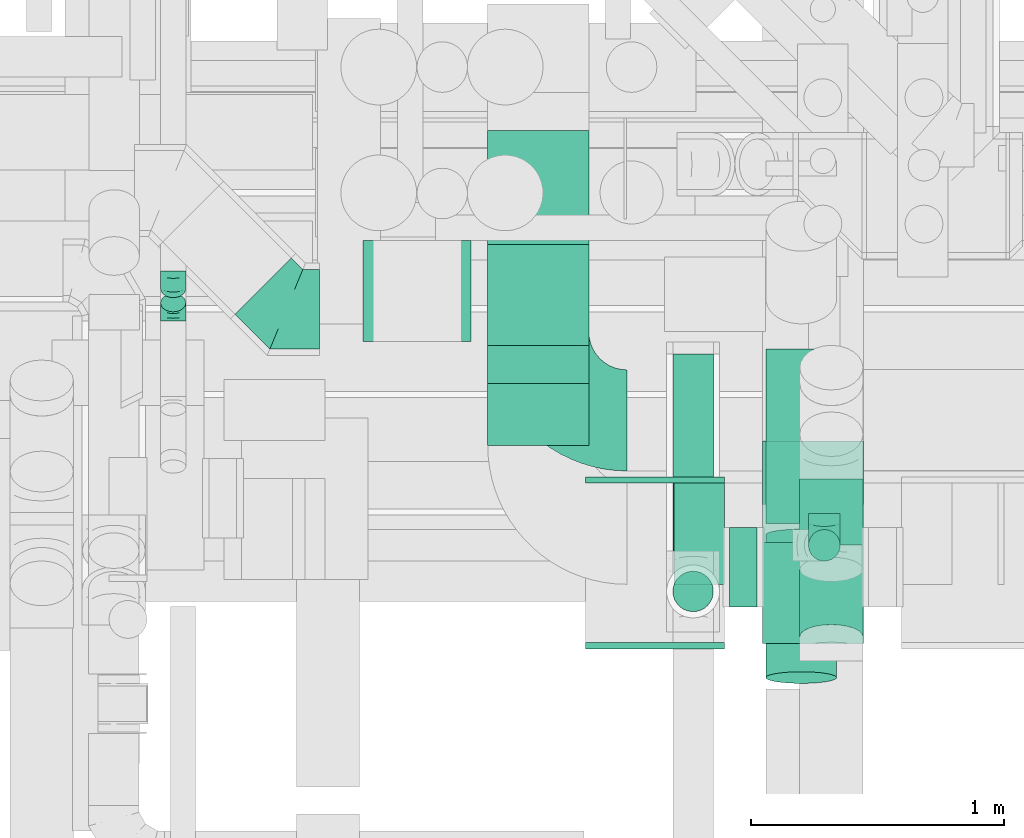
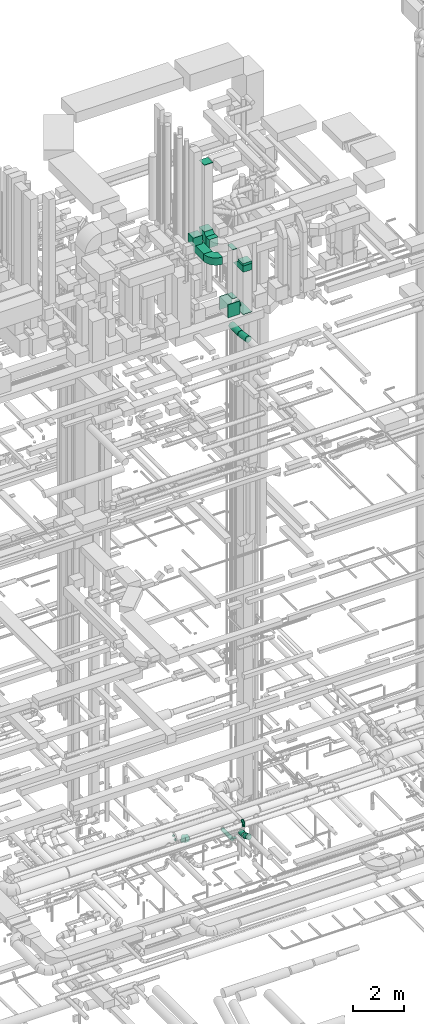
# One storey, part 221 of 337: 13 flow fittings, 12 flow segments.
"""IFC2X3 building model written with IfcOpenShell, lengths in millimetres."""

from ifc_helpers import new_model, entity, si_unit, converted_unit, derived_unit, direction, frame, frame_2d, origin, origin_2d_with_axis, place, context, subcontext, project, spatial, polyline, circle_curve, parameter, trimmed, segment, composite_curve, rectangle, circle, outline, extrude, faceted_brep, source, transform, mapped, material, type_object, type_shapes, element, save


model = new_model("IFC2X3")

# Units and contexts
model_context = context("Model", 3, precision=0.01, world=origin(), true_north=direction((6.12303176911189e-17, 1.0)))
body_context = subcontext(model_context, "Body", "Model", "MODEL_VIEW")
ifc_project = project(units=[si_unit("LENGTHUNIT", "METRE", prefix="MILLI"), si_unit("AREAUNIT", "SQUARE_METRE"), si_unit("VOLUMEUNIT", "CUBIC_METRE"), converted_unit("PLANEANGLEUNIT", "DEGREE", entity("IfcRatioMeasure", 0.0174532925199433), si_unit("PLANEANGLEUNIT", "RADIAN"), dimensions=[0, 0, 0, 0, 0, 0, 0]), si_unit("MASSUNIT", "GRAM", prefix="KILO"), derived_unit("MASSDENSITYUNIT", [(si_unit("MASSUNIT", "GRAM", prefix="KILO"), 1), (si_unit("LENGTHUNIT", "METRE"), -3)]), derived_unit("MOMENTOFINERTIAUNIT", [(si_unit("LENGTHUNIT", "METRE"), 4)]), si_unit("TIMEUNIT", "SECOND"), si_unit("FREQUENCYUNIT", "HERTZ"), si_unit("THERMODYNAMICTEMPERATUREUNIT", "DEGREE_CELSIUS"), derived_unit("THERMALTRANSMITTANCEUNIT", [(si_unit("MASSUNIT", "GRAM", prefix="KILO"), 1), (si_unit("THERMODYNAMICTEMPERATUREUNIT", "KELVIN"), -1), (si_unit("TIMEUNIT", "SECOND"), -3)]), derived_unit("VOLUMETRICFLOWRATEUNIT", [(si_unit("LENGTHUNIT", "METRE"), 3), (si_unit("TIMEUNIT", "SECOND"), -1)]), derived_unit("MASSFLOWRATEUNIT", [(si_unit("MASSUNIT", "GRAM", prefix="KILO"), 1), (si_unit("TIMEUNIT", "SECOND"), -1)]), derived_unit("ROTATIONALFREQUENCYUNIT", [(si_unit("TIMEUNIT", "SECOND"), -1)]), si_unit("ELECTRICCURRENTUNIT", "AMPERE"), si_unit("ELECTRICVOLTAGEUNIT", "VOLT"), si_unit("POWERUNIT", "WATT"), si_unit("FORCEUNIT", "NEWTON", prefix="KILO"), si_unit("ILLUMINANCEUNIT", "LUX"), si_unit("LUMINOUSFLUXUNIT", "LUMEN"), si_unit("LUMINOUSINTENSITYUNIT", "CANDELA"), derived_unit("USERDEFINED", [(si_unit("MASSUNIT", "GRAM", prefix="KILO"), -1), (si_unit("LENGTHUNIT", "METRE"), -2), (si_unit("TIMEUNIT", "SECOND"), 3), (si_unit("LUMINOUSFLUXUNIT", "LUMEN"), 1)]), derived_unit("LINEARVELOCITYUNIT", [(si_unit("LENGTHUNIT", "METRE"), 1), (si_unit("TIMEUNIT", "SECOND"), -1)]), si_unit("PRESSUREUNIT", "PASCAL"), derived_unit("USERDEFINED", [(si_unit("LENGTHUNIT", "METRE"), -2), (si_unit("MASSUNIT", "GRAM", prefix="KILO"), 1), (si_unit("TIMEUNIT", "SECOND"), -2)]), derived_unit("LINEARFORCEUNIT", [(si_unit("MASSUNIT", "GRAM", prefix="KILO"), 1), (si_unit("LENGTHUNIT", "METRE"), 1), (si_unit("TIMEUNIT", "SECOND"), -2), (si_unit("LENGTHUNIT", "METRE"), -1)]), derived_unit("PLANARFORCEUNIT", [(si_unit("MASSUNIT", "GRAM", prefix="KILO"), 1), (si_unit("LENGTHUNIT", "METRE"), 1), (si_unit("TIMEUNIT", "SECOND"), -2), (si_unit("LENGTHUNIT", "METRE"), -2)])], contexts=[model_context])

# Site, building, storey
site_placement = place(None, origin())
site = spatial("IfcSite", under=ifc_project, at=site_placement, CompositionType="ELEMENT")
building_placement = place(site_placement, origin())
building = spatial("IfcBuilding", under=site, at=building_placement, CompositionType="ELEMENT")
storey_placement = place(building_placement, origin())
storey = spatial("IfcBuildingStorey", under=building, at=storey_placement, CompositionType="ELEMENT", Elevation=0.0)

# Flow segments
duct_segment_type_1 = type_object("IfcDuctSegmentType", PredefinedType="NOTDEFINED")
flow_segment_1_placement = place(storey_placement, frame((55811.0, 9186.6, 30600.0)))
element("IfcFlowSegment", 1, at=flow_segment_1_placement, inside=storey, type_object=duct_segment_type_1, context=body_context, shape_type="SweptSolid", body=[
    extrude(rectangle(XDim=796.396645000123, YDim=399.999999999996, at=origin_2d_with_axis()), frame((200.0, 398.2, 0.0), z_axis=(0.0, 0.0, 1.0), x_axis=(0.0, 1.0, 0.0)), (0.0, 0.0, 1.0), 349.999999999998),
])
flow_segment_2_placement = place(storey_placement, frame((56897.0, 7954.29, 30732.17)))
element("IfcFlowSegment", 2, at=flow_segment_2_placement, inside=storey, type_object=duct_segment_type_1, context=body_context, shape_type="SweptSolid", body=[
    extrude(rectangle(XDim=399.999999999996, YDim=400.0, at=origin_2d_with_axis()), frame((200.0, 200.0, 0.0)), (0.0, 0.0, 1.0), 117.830633338824),
])
flow_segment_3_placement = place(storey_placement, frame((55811.0, 8738.29, 31500.0)))
element("IfcFlowSegment", 3, at=flow_segment_3_placement, inside=storey, type_object=duct_segment_type_1, context=body_context, shape_type="SweptSolid", body=[
    extrude(rectangle(XDim=244.711194999999, YDim=399.999999999996, at=origin_2d_with_axis()), frame((200.0, 122.36, 0.0), z_axis=(0.0, 0.0, 1.0), x_axis=(0.0, 1.0, 0.0)), (0.0, 0.0, 1.0), 399.999999999996),
])
flow_segment_4_placement = place(storey_placement, frame((55318.0, 9148.0, 31500.0)))
element("IfcFlowSegment", 4, at=flow_segment_4_placement, inside=storey, type_object=duct_segment_type_1, context=body_context, shape_type="SweptSolid", body=[
    extrude(rectangle(XDim=427.499999999998, YDim=400.0, at=origin_2d_with_axis()), frame((213.75, 200.0, 0.0)), (0.0, 0.0, 1.0), 399.999999999996),
])
duct_segment_type_2 = type_object("IfcDuctSegmentType", PredefinedType="NOTDEFINED")
flow_segment_5_placement = place(storey_placement, frame((57078.31, 8278.42, 3525.0)))
element("IfcFlowSegment", 5, at=flow_segment_5_placement, inside=storey, type_object=duct_segment_type_2, context=body_context, shape_type="SweptSolid", body=[
    extrude(circle(Radius=62.5, at=origin_2d_with_axis()), frame((64.1, 64.1, 0.0), z_axis=(0.0, 0.0, 1.0), x_axis=(0.0, 1.0, 0.0)), (0.0, 0.0, 1.0), 84.9999999999742),
])
flow_segment_6_placement = place(storey_placement, frame((56909.56, 8429.56, 27017.13)))
element("IfcFlowSegment", 6, at=flow_segment_6_placement, inside=storey, type_object=duct_segment_type_2, context=body_context, shape_type="SweptSolid", body=[
    extrude(circle(Radius=140.0, at=origin_2d_with_axis()), frame((141.6, 0.0, 141.6), z_axis=(0.0, 1.0, 0.0), x_axis=(-1.0, 0.0, 0.0)), (0.0, 0.0, 1.0), 689.86615875724),
])
flow_segment_7_placement = place(storey_placement, frame((56767.0, 8097.11, 28635.9)))
element("IfcFlowSegment", 7, at=flow_segment_7_placement, inside=storey, type_object=duct_segment_type_2, context=body_context, shape_type="SweptSolid", body=[
    extrude(circle(Radius=157.5, at=origin_2d_with_axis()), frame((0.0, 159.1, 159.1), z_axis=(1.0, 0.0, 0.0), x_axis=(0.0, -1.0, 0.0)), (0.0, 0.0, 1.0), 109.999999999984),
])
flow_segment_8_placement = place(storey_placement, frame((56541.69, 8320.18, 3018.4)))
element("IfcFlowSegment", 8, at=flow_segment_8_placement, inside=storey, type_object=duct_segment_type_2, context=body_context, shape_type="SweptSolid", body=[
    extrude(circle(Radius=80.0, at=origin_2d_with_axis()), frame((81.6, 0.0, 81.6), z_axis=(0.0, 1.0, 0.0), x_axis=(1.0, 0.0, 0.0)), (0.0, 0.0, 1.0), 778.202491666926),
])
flow_segment_9_placement = place(storey_placement, frame((56541.69, 8078.58, 3260.0)))
element("IfcFlowSegment", 9, at=flow_segment_9_placement, inside=storey, type_object=duct_segment_type_2, context=body_context, shape_type="SweptSolid", body=[
    extrude(circle(Radius=80.0, at=origin_2d_with_axis()), frame((81.6, 81.6, 0.0), z_axis=(0.0, 0.0, 1.0), x_axis=(-1.0, 0.0, 0.0)), (0.0, 0.0, 1.0), 10.000000000041),
])
flow_segment_10_placement = place(storey_placement, frame((57043.49, 8343.62, 2973.4)))
element("IfcFlowSegment", 10, at=flow_segment_10_placement, inside=storey, type_object=duct_segment_type_2, context=body_context, shape_type="SweptSolid", body=[
    extrude(circle(Radius=125.0, at=origin_2d_with_axis()), frame((126.6, 0.0, 126.6), z_axis=(0.0, 1.0, 0.0), x_axis=(1.0, 0.0, 0.0)), (0.0, 0.0, 1.0), 261.453983368941),
])
flow_segment_11_placement = place(storey_placement, frame((57043.49, 7930.94, 3002.39)))
element("IfcFlowSegment", 11, at=flow_segment_11_placement, inside=storey, type_object=duct_segment_type_2, context=body_context, shape_type="SweptSolid", body=[
    extrude(circle(Radius=125.0, at=origin_2d_with_axis()), frame((126.6, 49.78, 228.28), z_axis=(0.0, 0.922703438537182, -0.385510524514779), x_axis=(1.0, 0.0, 0.0)), (0.0, 0.0, 1.0), 288.842229168061),
])
flow_segment_12_placement = place(storey_placement, frame((56909.56, 7794.82, 27022.8)))
element("IfcFlowSegment", 12, at=flow_segment_12_placement, inside=storey, type_object=duct_segment_type_2, context=body_context, shape_type="SweptSolid", body=[
    extrude(circle(Radius=140.0, at=origin_2d_with_axis()), frame((141.6, 24.53, 233.42), z_axis=(0.0, 0.986491843597677, -0.163810385858946), x_axis=(-1.0, 0.0, 0.0)), (0.0, 0.0, 1.0), 572.07644729215),
])

# Flow fittings
ifc_material = material()
duct_fitting_type_1 = type_object("IfcDuctFittingType", PredefinedType="NOTDEFINED", material=ifc_material)
shared_shape_1 = source(origin(), body_context, "Body", "SweptSolid", [
    extrude(rectangle(XDim=200.0, YDim=26.096, at=origin_2d_with_axis()), frame((6.95, 0.0, -200.0), z_axis=(0.0, 0.0, 1.0), x_axis=(0.0, -1.0, 0.0)), (0.0, 0.0, 1.0), 400.0),
])
type_shapes(duct_fitting_type_1, [shared_shape_1])
for number, where, z_axis, x_axis in (
    (13, (56647.0, 8388.29, 29132.0), (0.0, 1.0, 0.0), (0.0, 0.0, 1.0)),
    (14, (56647.0, 8388.29, 31500.0), (0.0, 1.0, 0.0), (0.0, 0.0, -1.0)),
):
    element("IfcFlowFitting", number, at=place(storey_placement, frame(where, z_axis=z_axis, x_axis=x_axis)), inside=storey, type_object=duct_fitting_type_1, material=ifc_material, context=body_context, shape_type="MappedRepresentation", body=[
        mapped(shared_shape_1, transform((0.0, 0.0, 0.0), scale=1.0)),
    ])
duct_fitting_type_2 = type_object("IfcDuctFittingType", PredefinedType="NOTDEFINED", material=ifc_material)
shared_shape_2 = source(origin(), body_context, "Body", "SweptSolid", [
    extrude(rectangle(XDim=24.9999999999999, YDim=400.0, at=origin_2d_with_axis()), frame((12.5, 0.0, -200.0)), (0.0, 0.0, 1.0), 400.0),
])
type_shapes(duct_fitting_type_2, [shared_shape_2])
flow_fitting_1_placement = place(storey_placement, frame((56011.0, 9333.0, 35225.17), z_axis=(0.0, -1.0, 0.0), x_axis=(0.0, 0.0, 1.0)))
element("IfcFlowFitting", 15, at=flow_fitting_1_placement, inside=storey, type_object=duct_fitting_type_2, material=ifc_material, context=body_context, shape_type="MappedRepresentation", body=[
    mapped(shared_shape_2, transform((0.0, 0.0, 0.0), scale=1.0)),
])
duct_fitting_type_3 = type_object("IfcDuctFittingType", PredefinedType="NOTDEFINED", material=ifc_material)
shared_shape_3 = source(origin(), body_context, "Body", "SweptSolid", [
    extrude(outline(polyline([(-9.99, -180.02), (489.95, -180.02), (-150.0, 300.04), (-329.96, 60.01), (-9.99, -180.02)])), frame((150.0, -200.0, 99.96), z_axis=(0.0, 1.0, 0.0), x_axis=(0.600077602249012, 0.0, 0.799941792431847)), (0.0, 0.0, 1.0), 400.0),
])
type_shapes(duct_fitting_type_3, [shared_shape_3])
flow_fitting_2_placement = place(storey_placement, frame((57097.0, 8154.29, 30732.17), z_axis=(0.0, 1.0, 0.0), x_axis=(0.0, 0.0, -1.0)))
element("IfcFlowFitting", 16, at=flow_fitting_2_placement, inside=storey, type_object=duct_fitting_type_3, material=ifc_material, context=body_context, shape_type="MappedRepresentation", body=[
    mapped(shared_shape_3, transform((0.0, 0.0, 0.0), scale=1.0)),
])
duct_fitting_type_4 = type_object("IfcDuctFittingType", PredefinedType="NOTDEFINED", material=ifc_material)
shared_shape_4 = source(origin(), body_context, "Body", "SweptSolid", [
    extrude(rectangle(XDim=24.9999999999999, YDim=550.0, at=origin_2d_with_axis()), frame((12.5, 0.0, -315.0)), (0.0, 0.0, 1.0), 630.0),
])
type_shapes(duct_fitting_type_4, [shared_shape_4])
for number, where, z_axis, x_axis in (
    (17, (56472.0, 8588.29, 28817.0), (0.0, 0.0, 1.0), (0.0, 1.0, 0.0)),
    (18, (56472.0, 7958.29, 28817.0), (0.0, 0.0, 1.0), (0.0, -1.0, 0.0)),
):
    element("IfcFlowFitting", number, at=place(storey_placement, frame(where, z_axis=z_axis, x_axis=x_axis)), inside=storey, type_object=duct_fitting_type_4, material=ifc_material, context=body_context, shape_type="MappedRepresentation", body=[
        mapped(shared_shape_4, transform((0.0, 0.0, 0.0), scale=1.0)),
    ])
duct_fitting_type_5 = type_object("IfcDuctFittingType", PredefinedType="NOTDEFINED", material=ifc_material)
shared_shape_5 = source(origin(), body_context, "Body", "SweptSolid", [
    extrude(rectangle(XDim=24.9999999999999, YDim=800.0, at=origin_2d_with_axis()), frame((12.5, 0.0, -200.0)), (0.0, 0.0, 1.0), 400.0),
])
type_shapes(duct_fitting_type_5, [shared_shape_5])
flow_fitting_3_placement = place(storey_placement, frame((57097.0, 8354.21, 28417.57), z_axis=(1.0, 0.0, 0.0), x_axis=(0.0, 0.0, -1.0)))
element("IfcFlowFitting", 19, at=flow_fitting_3_placement, inside=storey, type_object=duct_fitting_type_5, material=ifc_material, context=body_context, shape_type="MappedRepresentation", body=[
    mapped(shared_shape_5, transform((0.0, 0.0, 0.0), scale=1.0)),
])
duct_fitting_type_6 = type_object("IfcDuctFittingType", PredefinedType="NOTDEFINED", material=ifc_material)
shared_shape_6 = source(origin(), body_context, "Body", "Brep", [
    faceted_brep([(-125.0, 0.0, -62.5), (-125.0, -16.18, -60.37), (-125.0, -31.25, -54.13), (-125.0, -44.19, -44.19), (-125.0, -54.13, -31.25), (-125.0, -60.37, -16.18), (-125.0, -62.5, 0.0), (-125.0, -60.37, 16.18), (-125.0, -54.13, 31.25), (-125.0, -44.19, 44.19), (-125.0, -31.25, 54.13), (-125.0, -16.18, 60.37), (-125.0, 0.0, 62.5), (-125.0, 16.18, 60.37), (-125.0, 31.25, 54.13), (-125.0, 44.19, 44.19), (-125.0, 54.13, 31.25), (-125.0, 60.37, 16.18), (-125.0, 62.5, 0.0), (-125.0, 60.37, -16.18), (-125.0, 54.13, -31.25), (-125.0, 44.19, -44.19), (-125.0, 31.25, -54.13), (-125.0, 16.18, -60.37), (-95.84, 16.18, 60.37), (-99.88, 31.25, 54.13), (-91.51, 0.0, 62.5), (-103.35, 44.19, 44.19), (-107.68, 60.37, 16.18), (-108.25, 62.5, 0.0), (-106.01, 54.13, 31.25), (-106.01, 54.13, -31.25), (-103.35, 44.19, -44.19), (-107.68, 60.37, -16.18), (-95.84, 16.18, -60.37), (-91.51, 0.0, -62.5), (-99.88, 31.25, -54.13), (-87.17, -16.18, -60.37), (-83.13, -31.25, -54.13), (-79.66, -44.19, -44.19), (-77.0, -54.13, -31.25), (-75.33, -60.37, -16.18), (-74.76, -62.5, 0.0), (-75.33, -60.37, 16.18), (-77.0, -54.13, 31.25), (-79.66, -44.19, 44.19), (-83.13, -31.25, 54.13), (-87.17, -16.18, 60.37), (-45.34, 45.34, 60.37), (-56.37, 56.37, 54.13), (-33.49, 33.49, 62.5), (-65.85, 65.85, 44.19), (-73.12, 73.12, 31.25), (-77.69, 77.69, 16.18), (-79.25, 79.25, 0.0), (-77.69, 77.69, -16.18), (-73.12, 73.12, -31.25), (-65.85, 65.85, -44.19), (-45.34, 45.34, -60.37), (-33.49, 33.49, -62.5), (-56.37, 56.37, -54.13), (-21.65, 21.65, -60.37), (-10.62, 10.62, -54.13), (-1.14, 1.14, -44.19), (6.13, -6.13, -31.25), (10.7, -10.7, -16.18), (12.26, -12.26, 0.0), (10.7, -10.7, 16.18), (6.13, -6.13, 31.25), (-1.14, 1.14, 44.19), (-10.62, 10.62, 54.13), (-21.65, 21.65, 60.37), (-16.18, 95.84, 60.37), (-31.25, 99.88, 54.13), (0.0, 91.51, 62.5), (-44.19, 103.35, 44.19), (-54.13, 106.01, 31.25), (-60.37, 107.68, 16.18), (-62.5, 108.25, 0.0), (-60.37, 107.68, -16.18), (-54.13, 106.01, -31.25), (-44.19, 103.35, -44.19), (-16.18, 95.84, -60.37), (0.0, 91.51, -62.5), (-31.25, 99.88, -54.13), (16.18, 87.17, -60.37), (31.25, 83.13, -54.13), (44.19, 79.66, -44.19), (54.13, 77.0, -31.25), (60.37, 75.33, -16.18), (62.5, 74.76, 0.0), (60.37, 75.33, 16.18), (54.13, 77.0, 31.25), (44.19, 79.66, 44.19), (31.25, 83.13, 54.13), (16.18, 87.17, 60.37), (-16.18, 125.0, -60.37), (-31.25, 125.0, -54.13), (-44.19, 125.0, -44.19), (-54.13, 125.0, -31.25), (-60.37, 125.0, -16.18), (-62.5, 125.0, 0.0), (-60.37, 125.0, 16.18), (-54.13, 125.0, 31.25), (-44.19, 125.0, 44.19), (-31.25, 125.0, 54.13), (-16.18, 125.0, 60.37), (0.0, 125.0, 62.5), (16.18, 125.0, 60.37), (31.25, 125.0, 54.13), (44.19, 125.0, 44.19), (54.13, 125.0, 31.25), (60.37, 125.0, 16.18), (62.5, 125.0, 0.0), (60.37, 125.0, -16.18), (54.13, 125.0, -31.25), (44.19, 125.0, -44.19), (31.25, 125.0, -54.13), (16.18, 125.0, -60.37), (0.0, 125.0, -62.5)], [[[0, 1, 2, 3, 4, 5, 6, 7, 8, 9, 10, 11, 12, 13, 14, 15, 16, 17, 18, 19, 20, 21, 22, 23]], [[24, 25, 14, 13]], [[26, 24, 13, 12]], [[14, 25, 27, 15]], [[28, 29, 18, 17]], [[30, 28, 17, 16]], [[15, 27, 30, 16]], [[20, 31, 32, 21]], [[33, 31, 20, 19]], [[18, 29, 33, 19]], [[34, 35, 0, 23]], [[36, 34, 23, 22]], [[21, 32, 36, 22]], [[1, 0, 35, 37]], [[2, 1, 37, 38]], [[38, 39, 3, 2]], [[5, 4, 40, 41]], [[6, 5, 41, 42]], [[39, 40, 4, 3]], [[6, 42, 43, 7]], [[7, 43, 44, 8]], [[45, 9, 8, 44]], [[9, 45, 46, 10]], [[10, 46, 47, 11]], [[26, 12, 11, 47]], [[48, 49, 25, 24]], [[50, 48, 24, 26]], [[27, 25, 49, 51]], [[52, 53, 28, 30]], [[51, 52, 30, 27]], [[29, 28, 53, 54]], [[55, 56, 31, 33]], [[54, 55, 33, 29]], [[57, 32, 31, 56]], [[58, 59, 35, 34]], [[60, 58, 34, 36]], [[57, 60, 36, 32]], [[37, 35, 59, 61]], [[38, 37, 61, 62]], [[39, 38, 62, 63]], [[41, 40, 64, 65]], [[42, 41, 65, 66]], [[63, 64, 40, 39]], [[43, 42, 66, 67]], [[44, 43, 67, 68]], [[68, 69, 45, 44]], [[46, 45, 69, 70]], [[47, 46, 70, 71]], [[26, 47, 71, 50]], [[72, 73, 49, 48]], [[74, 72, 48, 50]], [[51, 49, 73, 75]], [[76, 77, 53, 52]], [[75, 76, 52, 51]], [[54, 53, 77, 78]], [[79, 80, 56, 55]], [[78, 79, 55, 54]], [[81, 57, 56, 80]], [[82, 83, 59, 58]], [[84, 82, 58, 60]], [[81, 84, 60, 57]], [[61, 59, 83, 85]], [[62, 61, 85, 86]], [[63, 62, 86, 87]], [[65, 64, 88, 89]], [[66, 65, 89, 90]], [[87, 88, 64, 63]], [[67, 66, 90, 91]], [[68, 67, 91, 92]], [[92, 93, 69, 68]], [[70, 69, 93, 94]], [[71, 70, 94, 95]], [[50, 71, 95, 74]], [[96, 97, 98, 99, 100, 101, 102, 103, 104, 105, 106, 107, 108, 109, 110, 111, 112, 113, 114, 115, 116, 117, 118, 119]], [[72, 74, 107, 106]], [[73, 72, 106, 105]], [[75, 73, 105, 104]], [[77, 76, 103, 102]], [[78, 77, 102, 101]], [[75, 104, 103, 76]], [[78, 101, 100, 79]], [[79, 100, 99, 80]], [[80, 99, 98, 81]], [[96, 119, 83, 82]], [[97, 96, 82, 84]], [[84, 81, 98, 97]], [[83, 119, 118, 85]], [[85, 118, 117, 86]], [[116, 87, 86, 117]], [[88, 115, 114, 89]], [[89, 114, 113, 90]], [[115, 88, 87, 116]], [[91, 90, 113, 112]], [[92, 91, 112, 111]], [[111, 110, 93, 92]], [[95, 94, 109, 108]], [[74, 95, 108, 107]], [[110, 109, 94, 93]]]),
])
type_shapes(duct_fitting_type_6, [shared_shape_6])
flow_fitting_4_placement = place(storey_placement, frame((57142.4, 8342.51, 3735.0), z_axis=(1.0, 0.0, 0.0), x_axis=(0.0, -1.0, 0.0)))
element("IfcFlowFitting", 20, at=flow_fitting_4_placement, inside=storey, type_object=duct_fitting_type_6, material=ifc_material, context=body_context, shape_type="MappedRepresentation", body=[
    mapped(shared_shape_6, transform((0.0, 0.0, 0.0), scale=1.0)),
])
duct_fitting_type_7 = type_object("IfcDuctFittingType", PredefinedType="NOTDEFINED", material=ifc_material)
shared_shape_7 = source(origin(), body_context, "Body", "Brep", [
    faceted_brep([(-41.42, 0.0, -50.0), (-41.42, -12.94, -48.3), (-41.42, -25.0, -43.3), (-41.42, -35.36, -35.36), (-41.42, -43.3, -25.0), (-41.42, -48.3, -12.94), (-41.42, -50.0, 0.0), (-41.42, -48.3, 12.94), (-41.42, -43.3, 25.0), (-41.42, -35.36, 35.36), (-41.42, -25.0, 43.3), (-41.42, -12.94, 48.3), (-41.42, 0.0, 50.0), (-41.42, 12.94, 48.3), (-41.42, 25.0, 43.3), (-41.42, 35.36, 35.36), (-41.42, 43.3, 25.0), (-41.42, 48.3, 12.94), (-41.42, 50.0, 0.0), (-41.42, 48.3, -12.94), (-41.42, 43.3, -25.0), (-41.42, 35.36, -35.36), (-41.42, 25.0, -43.3), (-41.42, 12.94, -48.3), (-24.1, 12.94, 48.3), (-26.5, 25.0, 43.3), (-21.53, 0.0, 50.0), (-28.56, 35.36, 35.36), (-31.14, 48.3, 12.94), (-31.48, 50.0, 0.0), (-30.14, 43.3, 25.0), (-30.14, 43.3, -25.0), (-28.56, 35.36, -35.36), (-31.14, 48.3, -12.94), (-24.1, 12.94, -48.3), (-21.53, 0.0, -50.0), (-26.5, 25.0, -43.3), (-18.96, -12.94, -48.3), (-16.56, -25.0, -43.3), (-14.5, -35.36, -35.36), (-12.92, -43.3, -25.0), (-11.92, -48.3, -12.94), (-11.58, -50.0, 0.0), (-11.92, -48.3, 12.94), (-12.92, -43.3, 25.0), (-14.5, -35.36, 35.36), (-16.56, -25.0, 43.3), (-18.96, -12.94, 48.3), (7.89, 26.19, 48.3), (1.06, 36.42, 43.3), (15.22, 15.22, 50.0), (-4.8, 45.2, 35.36), (-12.13, 56.17, 12.94), (-13.1, 57.61, 0.0), (-9.3, 51.93, 25.0), (-9.3, 51.93, -25.0), (-4.8, 45.2, -35.36), (-12.13, 56.17, -12.94), (7.89, 26.19, -48.3), (15.22, 15.22, -50.0), (1.06, 36.42, -43.3), (22.55, 4.25, -48.3), (29.39, -5.97, -43.3), (35.25, -14.75, -35.36), (39.75, -21.48, -25.0), (42.58, -25.72, -12.94), (43.55, -27.16, 0.0), (42.58, -25.72, 12.94), (39.75, -21.48, 25.0), (35.25, -14.75, 35.36), (29.39, -5.97, 43.3), (22.55, 4.25, 48.3), (29.29, 29.29, 50.0), (20.14, 38.44, 48.3), (11.61, 46.97, 43.3), (4.29, 54.29, 35.36), (-1.33, 59.91, 25.0), (-4.86, 63.44, 12.94), (-6.07, 64.64, 0.0), (-4.86, 63.44, -12.94), (-1.33, 59.91, -25.0), (4.29, 54.29, -35.36), (11.61, 46.97, -43.3), (20.14, 38.44, -48.3), (29.29, 29.29, -50.0), (38.44, 20.14, -48.3), (46.97, 11.61, -43.3), (54.29, 4.29, -35.36), (59.91, -1.33, -25.0), (63.44, -4.86, -12.94), (64.64, -6.07, 0.0), (63.44, -4.86, 12.94), (59.91, -1.33, 25.0), (54.29, 4.29, 35.36), (46.97, 11.61, 43.3), (38.44, 20.14, 48.3)], [[[0, 1, 2, 3, 4, 5, 6, 7, 8, 9, 10, 11, 12, 13, 14, 15, 16, 17, 18, 19, 20, 21, 22, 23]], [[24, 25, 14, 13]], [[26, 24, 13, 12]], [[14, 25, 27, 15]], [[28, 29, 18, 17]], [[30, 28, 17, 16]], [[15, 27, 30, 16]], [[20, 31, 32, 21]], [[33, 31, 20, 19]], [[18, 29, 33, 19]], [[34, 35, 0, 23]], [[36, 34, 23, 22]], [[32, 36, 22, 21]], [[2, 1, 37, 38]], [[3, 2, 38, 39]], [[0, 35, 37, 1]], [[5, 4, 40, 41]], [[6, 5, 41, 42]], [[39, 40, 4, 3]], [[6, 42, 43, 7]], [[7, 43, 44, 8]], [[8, 44, 45, 9]], [[10, 46, 47, 11]], [[11, 47, 26, 12]], [[9, 45, 46, 10]], [[48, 49, 25, 24]], [[50, 48, 24, 26]], [[25, 49, 51, 27]], [[52, 53, 29, 28]], [[54, 52, 28, 30]], [[30, 27, 51, 54]], [[55, 56, 32, 31]], [[57, 55, 31, 33]], [[53, 57, 33, 29]], [[58, 59, 35, 34]], [[60, 58, 34, 36]], [[36, 32, 56, 60]], [[35, 59, 61, 37]], [[38, 37, 61, 62]], [[39, 38, 62, 63]], [[41, 40, 64, 65]], [[42, 41, 65, 66]], [[63, 64, 40, 39]], [[43, 42, 66, 67]], [[44, 43, 67, 68]], [[68, 69, 45, 44]], [[46, 45, 69, 70]], [[47, 46, 70, 71]], [[26, 47, 71, 50]], [[48, 50, 72, 73]], [[49, 48, 73, 74]], [[51, 49, 74, 75]], [[52, 54, 76, 77]], [[53, 52, 77, 78]], [[51, 75, 76, 54]], [[53, 78, 79, 57]], [[57, 79, 80, 55]], [[55, 80, 81, 56]], [[60, 82, 83, 58]], [[58, 83, 84, 59]], [[60, 56, 81, 82]], [[59, 84, 85, 61]], [[61, 85, 86, 62]], [[62, 86, 87, 63]], [[64, 88, 89, 65]], [[65, 89, 90, 66]], [[63, 87, 88, 64]], [[67, 66, 90, 91]], [[68, 67, 91, 92]], [[69, 68, 92, 93]], [[71, 70, 94, 95]], [[50, 71, 95, 72]], [[93, 94, 70, 69]], [[83, 82, 81, 80, 79, 78, 77, 76, 75, 74, 73, 72, 95, 94, 93, 92, 91, 90, 89, 88, 87, 86, 85, 84]]]),
])
type_shapes(duct_fitting_type_7, [shared_shape_7])
flow_fitting_5_placement = place(storey_placement, frame((54566.99, 9387.05, 3340.0), z_axis=(1.0, 0.0, 0.0), x_axis=(0.0, -1.0, -7.37136086970108e-07)))
element("IfcFlowFitting", 21, at=flow_fitting_5_placement, inside=storey, type_object=duct_fitting_type_7, material=ifc_material, context=body_context, shape_type="MappedRepresentation", body=[
    mapped(shared_shape_7, transform((0.0, 0.0, 0.0), scale=1.0)),
])
duct_fitting_type_8 = type_object("IfcDuctFittingType", PredefinedType="NOTDEFINED", material=ifc_material)
type_shapes(duct_fitting_type_8, [shared_shape_7])
flow_fitting_6_placement = place(storey_placement, frame((54566.99, 9272.05, 3225.0), z_axis=(-1.0, 0.0, 0.0), x_axis=(0.0, -0.707106160957612, -0.707107401414939)))
element("IfcFlowFitting", 22, at=flow_fitting_6_placement, inside=storey, type_object=duct_fitting_type_8, material=ifc_material, context=body_context, shape_type="MappedRepresentation", body=[
    mapped(shared_shape_7, transform((0.0, 0.0, 0.0), scale=1.0)),
])
duct_fitting_type_9 = type_object("IfcDuctFittingType", PredefinedType="NOTDEFINED", material=ifc_material)
shared_shape_8 = source(origin(), body_context, "Body", "Brep", [
    faceted_brep([(-130.48, 0.0, -157.5), (-130.48, -40.76, -152.13), (-130.48, -78.75, -136.4), (-130.48, -111.37, -111.37), (-130.48, -136.4, -78.75), (-130.48, -152.13, -40.76), (-130.48, -157.5, 0.0), (-130.48, -152.13, 40.76), (-130.48, -136.4, 78.75), (-130.48, -111.37, 111.37), (-130.48, -78.75, 136.4), (-130.48, -40.76, 152.13), (-130.48, 0.0, 157.5), (-130.48, 40.76, 152.13), (-130.48, 78.75, 136.4), (-130.48, 111.37, 111.37), (-130.48, 136.4, 78.75), (-130.48, 152.13, 40.76), (-130.48, 157.5, 0.0), (-130.48, 152.13, -40.76), (-130.48, 136.4, -78.75), (-130.48, 111.37, -111.37), (-130.48, 78.75, -136.4), (-130.48, 40.76, -152.13), (-16.89, 40.76, 152.13), (-32.62, 78.75, 136.4), (0.0, 0.0, 157.5), (-46.13, 111.37, 111.37), (-63.02, 152.13, 40.76), (-65.24, 157.5, 0.0), (-56.5, 136.4, 78.75), (-56.5, 136.4, -78.75), (-46.13, 111.37, -111.37), (-63.02, 152.13, -40.76), (-16.89, 40.76, -152.13), (0.0, 0.0, -157.5), (-32.62, 78.75, -136.4), (16.89, -40.76, -152.13), (32.62, -78.75, -136.4), (46.13, -111.37, -111.37), (56.5, -136.4, -78.75), (63.02, -152.13, -40.76), (65.24, -157.5, 0.0), (63.02, -152.13, 40.76), (56.5, -136.4, 78.75), (46.13, -111.37, 111.37), (32.62, -78.75, 136.4), (16.89, -40.76, 152.13), (92.26, 92.26, 157.5), (63.44, 121.09, 152.13), (36.58, 147.95, 136.4), (13.51, 171.01, 111.37), (-4.19, 188.71, 78.75), (-15.31, 199.84, 40.76), (-19.11, 203.63, 0.0), (-15.31, 199.84, -40.76), (-4.19, 188.71, -78.75), (13.51, 171.01, -111.37), (36.58, 147.95, -136.4), (63.44, 121.09, -152.13), (92.26, 92.26, -157.5), (121.09, 63.44, -152.13), (147.95, 36.58, -136.4), (171.01, 13.51, -111.37), (188.71, -4.19, -78.75), (199.84, -15.31, -40.76), (203.63, -19.11, 0.0), (199.84, -15.31, 40.76), (188.71, -4.19, 78.75), (171.01, 13.51, 111.37), (147.95, 36.58, 136.4), (121.09, 63.44, 152.13)], [[[0, 1, 2, 3, 4, 5, 6, 7, 8, 9, 10, 11, 12, 13, 14, 15, 16, 17, 18, 19, 20, 21, 22, 23]], [[24, 25, 14, 13]], [[26, 24, 13, 12]], [[14, 25, 27, 15]], [[28, 29, 18, 17]], [[30, 28, 17, 16]], [[15, 27, 30, 16]], [[20, 31, 32, 21]], [[33, 31, 20, 19]], [[18, 29, 33, 19]], [[34, 35, 0, 23]], [[36, 34, 23, 22]], [[32, 36, 22, 21]], [[1, 0, 35, 37]], [[2, 1, 37, 38]], [[38, 39, 3, 2]], [[5, 4, 40, 41]], [[6, 5, 41, 42]], [[39, 40, 4, 3]], [[6, 42, 43, 7]], [[7, 43, 44, 8]], [[8, 44, 45, 9]], [[9, 45, 46, 10]], [[10, 46, 47, 11]], [[26, 12, 11, 47]], [[24, 26, 48, 49]], [[25, 24, 49, 50]], [[27, 25, 50, 51]], [[28, 30, 52, 53]], [[29, 28, 53, 54]], [[51, 52, 30, 27]], [[55, 56, 31, 33]], [[54, 55, 33, 29]], [[57, 32, 31, 56]], [[36, 58, 59, 34]], [[34, 59, 60, 35]], [[58, 36, 32, 57]], [[35, 60, 61, 37]], [[37, 61, 62, 38]], [[63, 39, 38, 62]], [[40, 64, 65, 41]], [[41, 65, 66, 42]], [[64, 40, 39, 63]], [[43, 42, 66, 67]], [[44, 43, 67, 68]], [[68, 69, 45, 44]], [[47, 46, 70, 71]], [[26, 47, 71, 48]], [[69, 70, 46, 45]], [[54, 53, 52, 51, 50, 49, 48, 71, 70, 69, 68, 67, 66, 65, 64, 63, 62, 61, 60, 59, 58, 57, 56, 55]]]),
])
type_shapes(duct_fitting_type_9, [shared_shape_8])
flow_fitting_7_placement = place(storey_placement, frame((55014.36, 9275.88, 3100.0), z_axis=(3.17675879240644e-07, 3.17675879240605e-07, 1.0), x_axis=(0.707106781186505, -0.70710678118659, 0.0)))
element("IfcFlowFitting", 23, at=flow_fitting_7_placement, inside=storey, type_object=duct_fitting_type_9, material=ifc_material, context=body_context, shape_type="MappedRepresentation", body=[
    mapped(shared_shape_8, transform((0.0, 0.0, 0.0), scale=1.0)),
])
duct_fitting_type_10 = type_object("IfcDuctFittingType", PredefinedType="NOTDEFINED", material=ifc_material)
shared_shape_9 = source(origin(), body_context, "Body", "SweptSolid", [
    extrude(outline(composite_curve([segment(polyline([(-375.0, -175.0), (25.0, -175.0)]), True, "CONTINUOUS"), segment(trimmed(circle_curve(frame_2d((175.0, -175.0), x_axis=(0.0, 1.0)), 150.0), [parameter(0.0)], [parameter(90.0000000000001)], True, "PARAMETER"), False, "CONTINUOUS"), segment(polyline([(175.0, -25.0), (175.0, 375.0)]), True, "CONTINUOUS"), segment(trimmed(circle_curve(frame_2d((175.0, -175.0), x_axis=(0.0, 1.0)), 550.0), [parameter(0.0)], [parameter(90.0)], True, "PARAMETER"), True, "CONTINUOUS")], self_intersect=False)), frame((-175.0, 175.0, -175.0), z_axis=(0.0, 0.0, 1.0), x_axis=(-1.0, 0.0, 0.0)), (0.0, 0.0, 1.0), 350.0),
])
type_shapes(duct_fitting_type_10, [shared_shape_9])
flow_fitting_8_placement = place(storey_placement, frame((56011.0, 8836.6, 30775.0), z_axis=(0.0, 0.0, 1.0), x_axis=(0.0, -1.0, 0.0)))
element("IfcFlowFitting", 24, at=flow_fitting_8_placement, inside=storey, type_object=duct_fitting_type_10, material=ifc_material, context=body_context, shape_type="MappedRepresentation", body=[
    mapped(shared_shape_9, transform((0.0, 0.0, 0.0), scale=1.0)),
])
duct_fitting_type_11 = type_object("IfcDuctFittingType", PredefinedType="NOTDEFINED", material=ifc_material)
shared_shape_10 = source(origin(), body_context, "Body", "SweptSolid", [
    extrude(outline(composite_curve([segment(polyline([(-375.0, -175.0), (25.0, -175.0)]), True, "CONTINUOUS"), segment(trimmed(circle_curve(frame_2d((175.0, -175.0), x_axis=(0.0, 1.0)), 150.0), [parameter(0.0)], [parameter(90.0)], True, "PARAMETER"), False, "CONTINUOUS"), segment(polyline([(175.0, -25.0), (175.0, 375.0)]), True, "CONTINUOUS"), segment(trimmed(circle_curve(frame_2d((175.0, -175.0), x_axis=(0.0, 1.0)), 550.0), [parameter(0.0)], [parameter(90.0)], True, "PARAMETER"), True, "CONTINUOUS")], self_intersect=False)), frame((-175.0, 175.0, -200.0), z_axis=(0.0, 0.0, 1.0), x_axis=(-1.0, 0.0, 0.0)), (0.0, 0.0, 1.0), 400.0),
])
type_shapes(duct_fitting_type_11, [shared_shape_10])
flow_fitting_9_placement = place(storey_placement, frame((56011.0, 9333.0, 31700.0), z_axis=(1.0, 0.0, 0.0), x_axis=(0.0, 1.0, 0.0)))
element("IfcFlowFitting", 25, at=flow_fitting_9_placement, inside=storey, type_object=duct_fitting_type_11, material=ifc_material, context=body_context, shape_type="MappedRepresentation", body=[
    mapped(shared_shape_10, transform((0.0, 0.0, 0.0), scale=1.0)),
])

save(model, "model.ifc")
